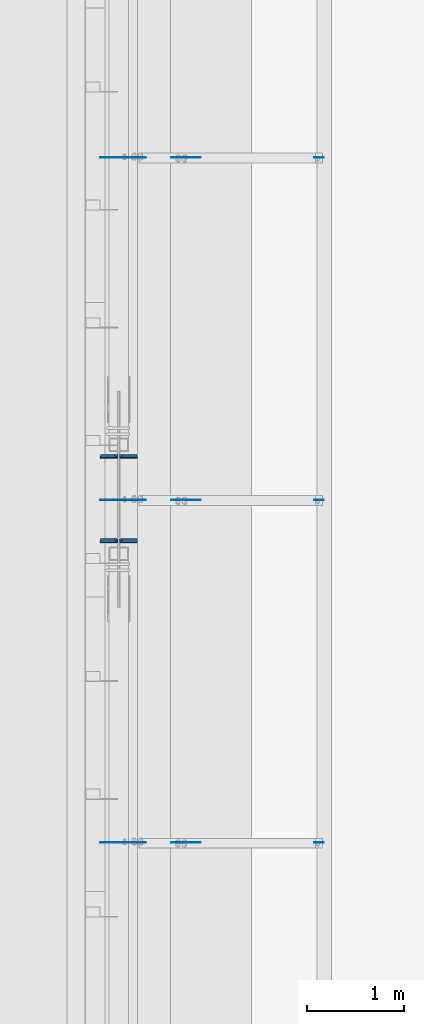
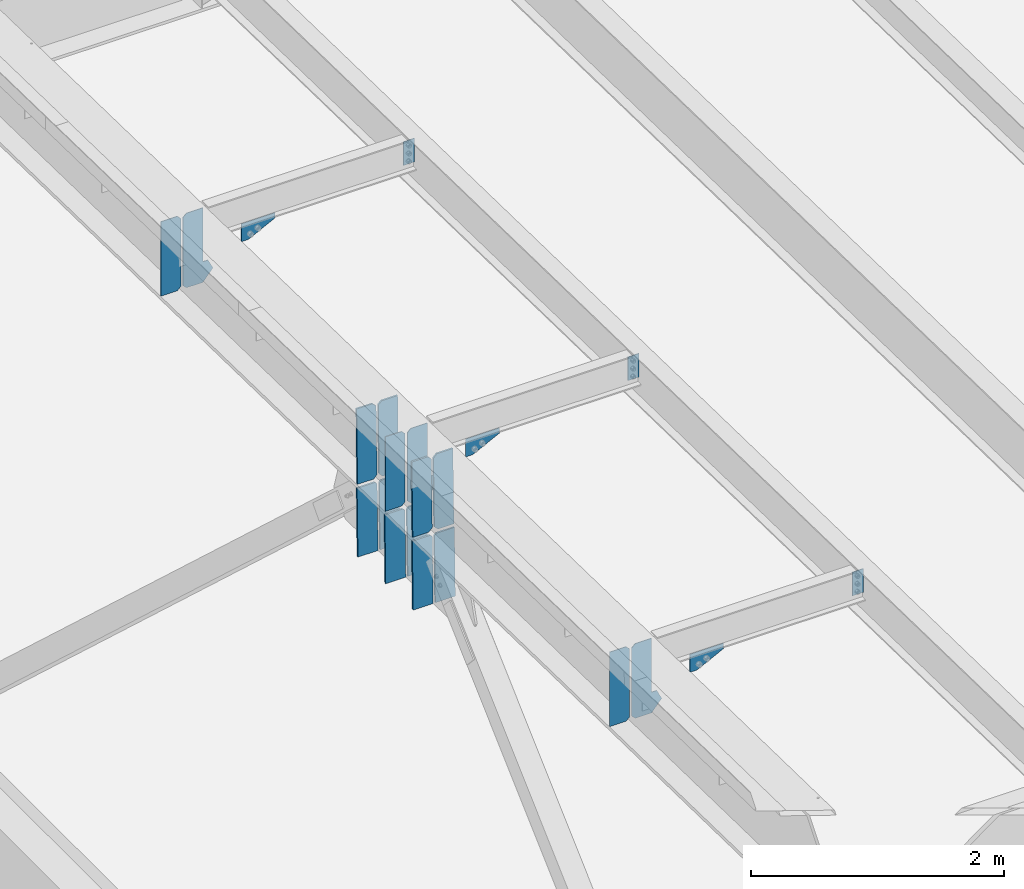
# One storey, part 1427 of 1763: 22 plates, 5 elements without a shape of their own.
"""IFC2X3 building model written with IfcOpenShell, lengths in millimetres."""

from ifc_helpers import new_model, si_unit, frame, origin_with_axes, place, context, subcontext, project, spatial, faceted_brep, material, type_object, element, aggregate, save


model = new_model("IFC2X3")

# Units and contexts
model_context = context("Model", 3, precision=1e-05, world=origin_with_axes())
body_context = subcontext(model_context, "Body", "Model", "MODEL_VIEW")
ifc_project = project(units=[si_unit("LENGTHUNIT", "METRE", prefix="MILLI"), si_unit("AREAUNIT", "SQUARE_METRE"), si_unit("VOLUMEUNIT", "CUBIC_METRE"), si_unit("MASSUNIT", "GRAM", prefix="KILO"), si_unit("TIMEUNIT", "SECOND"), si_unit("PLANEANGLEUNIT", "RADIAN"), si_unit("SOLIDANGLEUNIT", "STERADIAN"), si_unit("THERMODYNAMICTEMPERATUREUNIT", "DEGREE_CELSIUS"), si_unit("LUMINOUSINTENSITYUNIT", "LUMEN")], contexts=[model_context])

# Site, building, storey
site_placement = place(None, origin_with_axes())
site = spatial("IfcSite", under=ifc_project, at=site_placement, CompositionType="ELEMENT")
building_placement = place(site_placement, origin_with_axes())
building = spatial("IfcBuilding", under=site, at=building_placement, Name="Undefined", CompositionType="ELEMENT")
storey_placement = place(building_placement, origin_with_axes())
storey = spatial("IfcBuildingStorey", under=building, at=storey_placement, Name="Undefined", CompositionType="ELEMENT", Elevation=0.0)

# Assembly, plates
assembly_1_placement = place(storey_placement, origin_with_axes())
assembly_1 = element("IfcElementAssembly", 1, at=assembly_1_placement, inside=storey, Name="BEAM", AssemblyPlace="NOTDEFINED", PredefinedType="RIGID_FRAME")
ifc_material = material(Name="STEEL/A36")
plate_type_1 = type_object("IfcPlateType", PredefinedType="NOTDEFINED")
plate_1_placement = place(assembly_1_placement, frame((-85253.0631665555, -10166.3500000077, 12092.5240441116), z_axis=(-1.0, 0.0, 0.0), x_axis=(0.0, 0.0, -1.0)))
plate_1 = element("IfcPlate", 2, at=plate_1_placement, type_object=plate_type_1, material=ifc_material, Name="PLATE", context=body_context, shape_type="Brep", body=[
    faceted_brep([(1.81898940354586e-12, -3.17500000000291, 0.0), (0.0, -3.17499999999927, 101.599998474121), (0.0, 3.17499999999927, 101.599998474121), (-1.81898940354586e-12, 3.17499999997381, 0.0), (228.600006103516, -3.17499999999927, 101.599998474121), (228.600006103516, 3.17499999999927, 101.599998474121), (228.600006103516, -3.17500000001019, -7.27595761418343e-12), (228.600006103516, 3.17499999999563, -7.27595761418343e-12)], [[[0, 1, 2, 3]], [[1, 4, 5, 2]], [[4, 6, 7, 5]], [[6, 0, 3, 7]], [[5, 7, 3, 2]], [[6, 4, 1, 0]]]),
])
plate_2_placement = place(assembly_1_placement, frame((-85253.0631665555, -6623.04997029988, 12018.448086362), z_axis=(-1.0, 0.0, 0.0), x_axis=(0.0, 0.0, -1.0)))
plate_2 = element("IfcPlate", 3, at=plate_2_placement, type_object=plate_type_1, material=ifc_material, Name="PLATE", context=body_context, shape_type="Brep", body=[
    faceted_brep([(1.81898940354586e-12, -3.17500000000291, 0.0), (0.0, -3.17499999999927, 101.599998474121), (0.0, 3.17499999999927, 101.599998474121), (-1.81898940354586e-12, 3.17499999997381, 0.0), (228.600006103516, -3.17499999999927, 101.599998474121), (228.600006103516, 3.17499999999927, 101.599998474121), (228.600006103516, -3.17500000001019, -7.27595761418343e-12), (228.600006103516, 3.17499999999563, -7.27595761418343e-12)], [[[0, 1, 2, 3]], [[1, 4, 5, 2]], [[4, 6, 7, 5]], [[6, 0, 3, 7]], [[5, 7, 3, 2]], [[6, 4, 1, 0]]]),
])
plate_3_placement = place(assembly_1_placement, frame((-85253.0631665555, -3079.74999999648, 11944.3721298494), z_axis=(-1.0, 0.0, 0.0), x_axis=(0.0, 0.0, -1.0)))
plate_3 = element("IfcPlate", 4, at=plate_3_placement, type_object=plate_type_1, material=ifc_material, Name="PLATE", context=body_context, shape_type="Brep", body=[
    faceted_brep([(1.81898940354586e-12, -3.17500000000291, 0.0), (0.0, -3.17499999999927, 101.599998474121), (0.0, 3.17499999999927, 101.599998474121), (-1.81898940354586e-12, 3.17499999997381, 0.0), (228.600006103516, -3.17499999999927, 101.599998474121), (228.600006103516, 3.17499999999927, 101.599998474121), (228.600006103516, -3.17500000001019, -7.27595761418343e-12), (228.600006103516, 3.17499999999563, -7.27595761418343e-12)], [[[0, 1, 2, 3]], [[1, 4, 5, 2]], [[4, 6, 7, 5]], [[6, 0, 3, 7]], [[5, 7, 3, 2]], [[6, 4, 1, 0]]]),
])
aggregate(assembly_1, [plate_1, plate_2, plate_3])

assembly_2_placement = place(storey_placement, origin_with_axes())
assembly_2 = element("IfcElementAssembly", 5, at=assembly_2_placement, inside=storey, Name="BEAM", AssemblyPlace="NOTDEFINED", PredefinedType="RIGID_FRAME")
plate_type_2 = type_object("IfcPlateType", PredefinedType="NOTDEFINED")
plate_4_placement = place(assembly_2_placement, frame((-87384.9620473967, -3079.74999996299, 11230.3659606744), z_axis=(0.0, 0.0, 1.0), x_axis=(-1.0, 0.0, 0.0)))
plate_4 = element("IfcPlate", 6, at=plate_4_placement, type_object=plate_type_2, material=ifc_material, Name="PLATE", context=body_context, shape_type="Brep", body=[
    faceted_brep([(0.0, -3.17500000000291, 31.75), (0.0, -3.17499999999927, 686.812194824219), (0.0, 3.17499999999927, 686.812194824219), (0.0, 3.17500000000291, 31.75), (31.75, -3.17499999999927, 718.562194824219), (31.75, 3.17499999999927, 718.562194824219), (181.27522277832, -3.17500000000018, 718.562194824219), (181.27522277832, 3.17500000000018, 718.562194824219), (181.27522277832, -3.17500000000018, 0.0), (181.27522277832, 3.17500000000018, 0.0), (31.7499999999036, -3.17499999997381, 9.42916855706244e-11), (31.7499999998854, 3.17500000000291, 9.42916855706244e-11)], [[[0, 1, 2, 3]], [[1, 4, 5, 2]], [[4, 6, 7, 5]], [[6, 8, 9, 7]], [[8, 10, 11, 9]], [[10, 0, 3, 11]], [[5, 7, 9, 11, 3, 2]], [[10, 8, 6, 4, 1, 0]]]),
])
plate_5_placement = place(assembly_2_placement, frame((-87384.9620473967, -6623.04997026085, 11304.4419171798), z_axis=(0.0, 0.0, 1.0), x_axis=(-1.0, 0.0, 0.0)))
plate_5 = element("IfcPlate", 7, at=plate_5_placement, type_object=plate_type_2, material=ifc_material, Name="PLATE", context=body_context, shape_type="Brep", body=[
    faceted_brep([(0.0, -3.17500000000291, 31.75), (0.0, -3.17499999999927, 686.812194824219), (0.0, 3.17499999999927, 686.812194824219), (0.0, 3.17500000000291, 31.75), (31.75, -3.17499999999927, 718.562194824219), (31.75, 3.17499999999927, 718.562194824219), (181.27522277832, -3.17500000000018, 718.562194824219), (181.27522277832, 3.17500000000018, 718.562194824219), (181.27522277832, -3.17500000000018, 0.0), (181.27522277832, 3.17500000000018, 0.0), (31.7499999999036, -3.17499999997381, 9.42916855706244e-11), (31.7499999998854, 3.17500000000291, 9.42916855706244e-11)], [[[0, 1, 2, 3]], [[1, 4, 5, 2]], [[4, 6, 7, 5]], [[6, 8, 9, 7]], [[8, 10, 11, 9]], [[10, 0, 3, 11]], [[5, 7, 9, 11, 3, 2]], [[10, 8, 6, 4, 1, 0]]]),
])
plate_6_placement = place(assembly_2_placement, frame((-87384.9620473967, -10166.349999963, 11378.5178749269), z_axis=(0.0, 0.0, 1.0), x_axis=(-1.0, 0.0, 0.0)))
plate_6 = element("IfcPlate", 8, at=plate_6_placement, type_object=plate_type_2, material=ifc_material, Name="PLATE", context=body_context, shape_type="Brep", body=[
    faceted_brep([(0.0, -3.17500000000291, 31.75), (0.0, -3.17499999999927, 686.812194824219), (0.0, 3.17499999999927, 686.812194824219), (0.0, 3.17500000000291, 31.75), (31.75, -3.17499999999927, 718.562194824219), (31.75, 3.17499999999927, 718.562194824219), (181.27522277832, -3.17500000000018, 718.562194824219), (181.27522277832, 3.17500000000018, 718.562194824219), (181.27522277832, -3.17500000000018, 0.0), (181.27522277832, 3.17500000000018, 0.0), (31.7499999999036, -3.17499999997381, 9.42916855706244e-11), (31.7499999998854, 3.17500000000291, 9.42916855706244e-11)], [[[0, 1, 2, 3]], [[1, 4, 5, 2]], [[4, 6, 7, 5]], [[6, 8, 9, 7]], [[8, 10, 11, 9]], [[10, 0, 3, 11]], [[5, 7, 9, 11, 3, 2]], [[10, 8, 6, 4, 1, 0]]]),
])

# Assembly, plate
assembly_3_placement = place(storey_placement, origin_with_axes())
assembly_3 = element("IfcElementAssembly", 9, at=assembly_3_placement, inside=storey, Name="BEAM", AssemblyPlace="NOTDEFINED", PredefinedType="RIGID_FRAME")
plate_type_3 = type_object("IfcPlateType", PredefinedType="NOTDEFINED")
plate_7_placement = place(assembly_3_placement, frame((-86833.7627823412, -3079.75000001315, 11671.3220843818), z_axis=(1.0, 0.0, 0.0), x_axis=(0.0, 0.0, -1.0)))
plate_7 = element("IfcPlate", 10, at=plate_7_placement, type_object=plate_type_3, material=ifc_material, Name="PLATE", context=body_context, shape_type="Brep", body=[
    faceted_brep([(1.81898940354586e-12, -3.17500000000291, 0.0), (0.0, -3.17499999999927, 306.070465087891), (0.0, 3.17499999999927, 306.070465087891), (-1.81898940354586e-12, 3.17499999997381, 0.0), (50.7999992370605, -3.17499999999927, 306.070465087891), (50.7999992370605, 3.17499999999927, 306.070465087891), (172.922760009766, -3.17499999999927, 61.8249359130859), (172.922760009766, 3.17499999999927, 61.8249359130859), (172.922760009766, -3.17499999999927, 0.0), (172.922760009766, 3.17499999999927, 0.0)], [[[0, 1, 2, 3]], [[1, 4, 5, 2]], [[4, 6, 7, 5]], [[6, 8, 9, 7]], [[8, 0, 3, 9]], [[5, 7, 9, 3, 2]], [[8, 6, 4, 1, 0]]]),
])
aggregate(assembly_3, [plate_7])

assembly_4_placement = place(storey_placement, origin_with_axes())
assembly_4 = element("IfcElementAssembly", 11, at=assembly_4_placement, inside=storey, Name="BEAM", AssemblyPlace="NOTDEFINED", PredefinedType="RIGID_FRAME")
plate_8_placement = place(assembly_4_placement, frame((-86833.7627823412, -6623.04997031101, 11745.3980408872), z_axis=(1.0, 0.0, 0.0), x_axis=(0.0, 0.0, -1.0)))
plate_8 = element("IfcPlate", 12, at=plate_8_placement, type_object=plate_type_3, material=ifc_material, Name="PLATE", context=body_context, shape_type="Brep", body=[
    faceted_brep([(1.81898940354586e-12, -3.17500000000291, 0.0), (0.0, -3.17499999999927, 306.070465087891), (0.0, 3.17499999999927, 306.070465087891), (-1.81898940354586e-12, 3.17499999997381, 0.0), (50.7999992370605, -3.17499999999927, 306.070465087891), (50.7999992370605, 3.17499999999927, 306.070465087891), (172.922760009766, -3.17499999999927, 61.8249359130859), (172.922760009766, 3.17499999999927, 61.8249359130859), (172.922760009766, -3.17499999999927, 0.0), (172.922760009766, 3.17499999999927, 0.0)], [[[0, 1, 2, 3]], [[1, 4, 5, 2]], [[4, 6, 7, 5]], [[6, 8, 9, 7]], [[8, 0, 3, 9]], [[5, 7, 9, 3, 2]], [[8, 6, 4, 1, 0]]]),
])
aggregate(assembly_4, [plate_8])

assembly_5_placement = place(storey_placement, origin_with_axes())
assembly_5 = element("IfcElementAssembly", 13, at=assembly_5_placement, inside=storey, Name="BEAM", AssemblyPlace="NOTDEFINED", PredefinedType="RIGID_FRAME")
plate_9_placement = place(assembly_5_placement, frame((-86833.7627823412, -10166.3500000131, 11819.4739986343), z_axis=(1.0, 0.0, 0.0), x_axis=(0.0, 0.0, -1.0)))
plate_9 = element("IfcPlate", 14, at=plate_9_placement, type_object=plate_type_3, material=ifc_material, Name="PLATE", context=body_context, shape_type="Brep", body=[
    faceted_brep([(1.81898940354586e-12, -3.17500000000291, 0.0), (0.0, -3.17499999999927, 306.070465087891), (0.0, 3.17499999999927, 306.070465087891), (-1.81898940354586e-12, 3.17499999997381, 0.0), (50.7999992370605, -3.17499999999927, 306.070465087891), (50.7999992370605, 3.17499999999927, 306.070465087891), (172.922760009766, -3.17499999999927, 61.8249359130859), (172.922760009766, 3.17499999999927, 61.8249359130859), (172.922760009766, -3.17499999999927, 0.0), (172.922760009766, 3.17499999999927, 0.0)], [[[0, 1, 2, 3]], [[1, 4, 5, 2]], [[4, 6, 7, 5]], [[6, 8, 9, 7]], [[8, 0, 3, 9]], [[5, 7, 9, 3, 2]], [[8, 6, 4, 1, 0]]]),
])
aggregate(assembly_5, [plate_9])

# Plate
plate_type_4 = type_object("IfcPlateType", PredefinedType="NOTDEFINED")
plate_10_placement = place(assembly_2_placement, frame((-87365.9120473967, -3079.74999996487, 11230.3659606744), z_axis=(0.0, 0.0, 1.0), x_axis=(1.0, 0.0, 0.0)))
plate_10 = element("IfcPlate", 15, at=plate_10_placement, type_object=plate_type_4, material=ifc_material, Name="PLATE", context=body_context, shape_type="Brep", body=[
    faceted_brep([(0.0, -3.17500000000291, 31.75), (0.0, -3.17499999999927, 686.812255859375), (0.0, 3.17499999999927, 686.812255859375), (0.0, 3.17500000000291, 31.75), (31.75, -3.17499999999927, 718.562255859375), (31.75, 3.17499999999927, 718.562255859375), (182.562271118164, -3.17500000000018, 718.562255859375), (182.562271118164, 3.17500000000018, 718.562255859375), (182.562271118164, -3.17500000000018, 199.174194335938), (182.562271118164, 3.17500000000018, 199.174194335938), (229.018508911133, -3.17500000000018, 199.147766113281), (229.018508911133, 3.17500000000018, 199.147766113281), (274.455413818359, -3.17500000000018, 108.273963928223), (274.455413818359, 3.17500000000018, 108.273963928223), (182.562271118164, -3.17500000000018, 0.0), (182.562271118164, 3.17500000000018, 0.0), (31.7499999999036, -3.17499999997381, 9.42916855706244e-11), (31.7499999998854, 3.17500000000291, 9.42916855706244e-11)], [[[0, 1, 2, 3]], [[1, 4, 5, 2]], [[4, 6, 7, 5]], [[6, 8, 9, 7]], [[8, 10, 11, 9]], [[10, 12, 13, 11]], [[12, 14, 15, 13]], [[14, 16, 17, 15]], [[16, 0, 3, 17]], [[5, 7, 9, 11, 13, 15, 17, 3, 2]], [[16, 14, 12, 10, 8, 6, 4, 1, 0]]]),
])

plate_11_placement = place(assembly_2_placement, frame((-87365.9120473967, -6623.04997026273, 11304.4419171798), z_axis=(0.0, 0.0, 1.0), x_axis=(1.0, 0.0, 0.0)))
plate_11 = element("IfcPlate", 16, at=plate_11_placement, type_object=plate_type_4, material=ifc_material, Name="PLATE", context=body_context, shape_type="Brep", body=[
    faceted_brep([(0.0, -3.17500000000291, 31.75), (0.0, -3.17499999999927, 686.812255859375), (0.0, 3.17499999999927, 686.812255859375), (0.0, 3.17500000000291, 31.75), (31.75, -3.17499999999927, 718.562255859375), (31.75, 3.17499999999927, 718.562255859375), (182.562271118164, -3.17500000000018, 718.562255859375), (182.562271118164, 3.17500000000018, 718.562255859375), (182.562271118164, -3.17500000000018, 199.174194335938), (182.562271118164, 3.17500000000018, 199.174194335938), (229.018508911133, -3.17500000000018, 199.147766113281), (229.018508911133, 3.17500000000018, 199.147766113281), (274.455413818359, -3.17500000000018, 108.273963928223), (274.455413818359, 3.17500000000018, 108.273963928223), (182.562271118164, -3.17500000000018, 0.0), (182.562271118164, 3.17500000000018, 0.0), (31.7499999999036, -3.17499999997381, 9.42916855706244e-11), (31.7499999998854, 3.17500000000291, 9.42916855706244e-11)], [[[0, 1, 2, 3]], [[1, 4, 5, 2]], [[4, 6, 7, 5]], [[6, 8, 9, 7]], [[8, 10, 11, 9]], [[10, 12, 13, 11]], [[12, 14, 15, 13]], [[14, 16, 17, 15]], [[16, 0, 3, 17]], [[5, 7, 9, 11, 13, 15, 17, 3, 2]], [[16, 14, 12, 10, 8, 6, 4, 1, 0]]]),
])

plate_12_placement = place(assembly_2_placement, frame((-87365.9120473967, -10166.3499999649, 11378.5178749269), z_axis=(0.0, 0.0, 1.0), x_axis=(1.0, 0.0, 0.0)))
plate_12 = element("IfcPlate", 17, at=plate_12_placement, type_object=plate_type_4, material=ifc_material, Name="PLATE", context=body_context, shape_type="Brep", body=[
    faceted_brep([(0.0, -3.17500000000291, 31.75), (0.0, -3.17499999999927, 686.812255859375), (0.0, 3.17499999999927, 686.812255859375), (0.0, 3.17500000000291, 31.75), (31.75, -3.17499999999927, 718.562255859375), (31.75, 3.17499999999927, 718.562255859375), (182.562271118164, -3.17500000000018, 718.562255859375), (182.562271118164, 3.17500000000018, 718.562255859375), (182.562271118164, -3.17500000000018, 199.174194335938), (182.562271118164, 3.17500000000018, 199.174194335938), (229.018508911133, -3.17500000000018, 199.147766113281), (229.018508911133, 3.17500000000018, 199.147766113281), (274.455413818359, -3.17500000000018, 108.273963928223), (274.455413818359, 3.17500000000018, 108.273963928223), (182.562271118164, -3.17500000000018, 0.0), (182.562271118164, 3.17500000000018, 0.0), (31.7499999999036, -3.17499999997381, 9.42916855706244e-11), (31.7499999998854, 3.17500000000291, 9.42916855706244e-11)], [[[0, 1, 2, 3]], [[1, 4, 5, 2]], [[4, 6, 7, 5]], [[6, 8, 9, 7]], [[8, 10, 11, 9]], [[10, 12, 13, 11]], [[12, 14, 15, 13]], [[14, 16, 17, 15]], [[16, 0, 3, 17]], [[5, 7, 9, 11, 13, 15, 17, 3, 2]], [[16, 14, 12, 10, 8, 6, 4, 1, 0]]]),
])

plate_type_5 = type_object("IfcPlateType", PredefinedType="NOTDEFINED")
plate_13_placement = place(assembly_2_placement, frame((-87188.1122736984, -6173.93912562898, 11294.3868374917), z_axis=(0.0, 0.0209013539966291, 0.999781542838788), x_axis=(-1.0, 0.0, 0.0)))
plate_13 = element("IfcPlate", 18, at=plate_13_placement, type_object=plate_type_5, material=ifc_material, Name="PLATE", context=body_context, shape_type="Brep", body=[
    faceted_brep([(-7.27595761418343e-12, -7.9375, 0.0), (0.0, -7.93750000023556, 717.549987793544), (0.0, 7.93749999976308, 717.549987793549), (-7.27595761418343e-12, 7.9375, 0.0), (146.050003051758, -7.93750000023556, 717.549987793544), (146.050003051758, 7.93749999976308, 717.549987793549), (177.800003051758, -7.93750000022555, 685.799987793518), (177.800003051758, 7.93749999977354, 685.799987793525), (177.800003051758, -7.93750000001, 31.7500000000236), (177.800003051758, 7.93749999998863, 31.7500000000309), (146.050003051758, -7.9375, 0.0), (146.050003051758, 7.93749999999909, 3.63797880709171e-12)], [[[0, 1, 2, 3]], [[1, 4, 5, 2]], [[4, 6, 7, 5]], [[6, 8, 9, 7]], [[8, 10, 11, 9]], [[10, 0, 3, 11]], [[5, 7, 9, 11, 3, 2]], [[10, 8, 6, 4, 1, 0]]]),
])

plate_14_placement = place(assembly_2_placement, frame((-87384.9622736983, -6173.93912562898, 11294.3868374917), z_axis=(0.0, 0.0209013539966291, 0.999781542838788), x_axis=(-1.0, 0.0, 0.0)))
plate_14 = element("IfcPlate", 19, at=plate_14_placement, type_object=plate_type_5, material=ifc_material, Name="PLATE", context=body_context, shape_type="Brep", body=[
    faceted_brep([(0.0, -7.9375, 31.75), (0.0, -7.93750000022555, 685.799987793518), (0.0, 7.93749999977354, 685.799987793525), (0.0, 7.9375, 31.75), (31.75, -7.93750000023556, 717.549987793544), (31.75, 7.93749999976262, 717.549987793549), (177.800003051758, -7.93750000023556, 717.549987793544), (177.800003051758, 7.93749999976262, 717.549987793549), (177.800003051758, -7.9375, 0.0), (177.800003051758, 7.93749999999909, 3.63797880709171e-12), (31.75, -7.9375, 0.0), (31.75, 7.9375, 0.0)], [[[0, 1, 2, 3]], [[1, 4, 5, 2]], [[4, 6, 7, 5]], [[6, 8, 9, 7]], [[8, 10, 11, 9]], [[10, 0, 3, 11]], [[5, 7, 9, 11, 3, 2]], [[10, 8, 6, 4, 1, 0]]]),
])

plate_15_placement = place(assembly_2_placement, frame((-87188.1122736984, -7046.33856760696, 11312.6251530906), z_axis=(0.0, 0.0209013539966291, 0.999781542838788), x_axis=(-1.0, 0.0, 0.0)))
plate_15 = element("IfcPlate", 20, at=plate_15_placement, type_object=plate_type_5, material=ifc_material, Name="PLATE", context=body_context, shape_type="Brep", body=[
    faceted_brep([(-7.27595761418343e-12, -7.9375, 0.0), (0.0, -7.93750000023556, 717.549987793544), (0.0, 7.93749999976308, 717.549987793549), (-7.27595761418343e-12, 7.9375, 0.0), (146.050003051758, -7.93750000023556, 717.549987793544), (146.050003051758, 7.93749999976308, 717.549987793549), (177.800003051758, -7.93750000022555, 685.799987793518), (177.800003051758, 7.93749999977354, 685.799987793525), (177.800003051758, -7.93750000001, 31.7500000000236), (177.800003051758, 7.93749999998863, 31.7500000000309), (146.050003051758, -7.9375, 0.0), (146.050003051758, 7.93749999999909, 3.63797880709171e-12)], [[[0, 1, 2, 3]], [[1, 4, 5, 2]], [[4, 6, 7, 5]], [[6, 8, 9, 7]], [[8, 10, 11, 9]], [[10, 0, 3, 11]], [[5, 7, 9, 11, 3, 2]], [[10, 8, 6, 4, 1, 0]]]),
])

plate_16_placement = place(assembly_2_placement, frame((-87384.9622736983, -7046.33856760696, 11312.6251530906), z_axis=(0.0, 0.0209013539966291, 0.999781542838788), x_axis=(-1.0, 0.0, 0.0)))
plate_16 = element("IfcPlate", 21, at=plate_16_placement, type_object=plate_type_5, material=ifc_material, Name="PLATE", context=body_context, shape_type="Brep", body=[
    faceted_brep([(0.0, -7.9375, 31.75), (0.0, -7.93750000022555, 685.799987793518), (0.0, 7.93749999977354, 685.799987793525), (0.0, 7.9375, 31.75), (31.75, -7.93750000023556, 717.549987793544), (31.75, 7.93749999976262, 717.549987793549), (177.800003051758, -7.93750000023556, 717.549987793544), (177.800003051758, 7.93749999976262, 717.549987793549), (177.800003051758, -7.9375, 0.0), (177.800003051758, 7.93749999999909, 3.63797880709171e-12), (31.75, -7.9375, 0.0), (31.75, 7.9375, 0.0)], [[[0, 1, 2, 3]], [[1, 4, 5, 2]], [[4, 6, 7, 5]], [[6, 8, 9, 7]], [[8, 10, 11, 9]], [[10, 0, 3, 11]], [[5, 7, 9, 11, 3, 2]], [[10, 8, 6, 4, 1, 0]]]),
])

plate_type_6 = type_object("IfcPlateType", PredefinedType="NOTDEFINED")
plate_17_placement = place(assembly_2_placement, frame((-87384.9622736979, -7047.06804744363, 11277.7077722575), z_axis=(0.0, -0.0209013569953167, -0.999781542776098), x_axis=(-1.0, 0.0, 0.0)))
plate_17 = element("IfcPlate", 22, at=plate_17_placement, type_object=plate_type_6, material=ifc_material, Name="PLATE", context=body_context, shape_type="Brep", body=[
    faceted_brep([(-3.27418092638254e-10, -7.9375, 19.0499992370605), (0.0, -7.93750000021555, 655.64782714896), (0.0, 7.93749999978263, 655.647827148967), (-3.27418092638254e-10, 7.9375, 19.0499992370605), (182.5625, -7.93750000021555, 655.64782714896), (182.5625, 7.93749999978263, 655.647827148967), (182.5625, -7.9375, -5.45696821063757e-12), (182.5625, 7.93749999999909, -1.81898940354586e-12), (19.0499815529183, -7.9375, 0.0), (19.0499815529183, 7.9375, 0.0)], [[[0, 1, 2, 3]], [[1, 4, 5, 2]], [[4, 6, 7, 5]], [[6, 8, 9, 7]], [[8, 0, 3, 9]], [[5, 7, 9, 3, 2]], [[8, 6, 4, 1, 0]]]),
])

plate_18_placement = place(assembly_2_placement, frame((-87183.3497736981, -7047.06804744501, 11277.7077723329), z_axis=(0.0, -0.0209013569953167, -0.999781542776098), x_axis=(-1.0, 0.0, 0.0)))
plate_18 = element("IfcPlate", 23, at=plate_18_placement, type_object=plate_type_6, material=ifc_material, Name="PLATE", context=body_context, shape_type="Brep", body=[
    faceted_brep([(-7.27595761418343e-12, -7.9375, 0.0), (0.0, -7.93750000021555, 655.64782714896), (0.0, 7.93749999978263, 655.647827148967), (-7.27595761418343e-12, 7.9375, 0.0), (182.5625, -7.93750000021555, 655.64782714896), (182.5625, 7.93749999978263, 655.647827148967), (182.5625, -7.93750000000637, 19.0499992370715), (182.5625, 7.93749999999181, 19.0499992370769), (163.512500762939, -7.93750000000091, -3.63797880709171e-12), (163.512500762939, 7.93749999999818, 1.81898940354586e-12)], [[[0, 1, 2, 3]], [[1, 4, 5, 2]], [[4, 6, 7, 5]], [[6, 8, 9, 7]], [[8, 0, 3, 9]], [[5, 7, 9, 3, 2]], [[8, 6, 4, 1, 0]]]),
])

plate_19_placement = place(assembly_2_placement, frame((-87384.9622736981, -6174.66860545944, 11259.4694569555), z_axis=(0.0, -0.0209013569953167, -0.999781542776098), x_axis=(-1.0, 0.0, 0.0)))
plate_19 = element("IfcPlate", 24, at=plate_19_placement, type_object=plate_type_6, material=ifc_material, Name="PLATE", context=body_context, shape_type="Brep", body=[
    faceted_brep([(-3.27418092638254e-10, -7.9375, 19.0499992370605), (0.0, -7.93750000021555, 655.64782714896), (0.0, 7.93749999978263, 655.647827148967), (-3.27418092638254e-10, 7.9375, 19.0499992370605), (182.5625, -7.93750000021555, 655.64782714896), (182.5625, 7.93749999978263, 655.647827148967), (182.5625, -7.9375, -5.45696821063757e-12), (182.5625, 7.93749999999909, -1.81898940354586e-12), (19.0499815529183, -7.9375, 0.0), (19.0499815529183, 7.9375, 0.0)], [[[0, 1, 2, 3]], [[1, 4, 5, 2]], [[4, 6, 7, 5]], [[6, 8, 9, 7]], [[8, 0, 3, 9]], [[5, 7, 9, 3, 2]], [[8, 6, 4, 1, 0]]]),
])

plate_20_placement = place(assembly_2_placement, frame((-87384.9622736983, -6613.44300291686, 11268.6424400736), z_axis=(0.0, -0.0209013569953167, -0.999781542776098), x_axis=(-1.0, 0.0, 0.0)))
plate_20 = element("IfcPlate", 25, at=plate_20_placement, type_object=plate_type_6, material=ifc_material, Name="PLATE", context=body_context, shape_type="Brep", body=[
    faceted_brep([(-3.27418092638254e-10, -7.9375, 19.0499992370605), (0.0, -7.93750000021555, 655.64782714896), (0.0, 7.93749999978263, 655.647827148967), (-3.27418092638254e-10, 7.9375, 19.0499992370605), (182.5625, -7.93750000021555, 655.64782714896), (182.5625, 7.93749999978263, 655.647827148967), (182.5625, -7.9375, -5.45696821063757e-12), (182.5625, 7.93749999999909, -1.81898940354586e-12), (19.0499815529183, -7.9375, 0.0), (19.0499815529183, 7.9375, 0.0)], [[[0, 1, 2, 3]], [[1, 4, 5, 2]], [[4, 6, 7, 5]], [[6, 8, 9, 7]], [[8, 0, 3, 9]], [[5, 7, 9, 3, 2]], [[8, 6, 4, 1, 0]]]),
])

plate_21_placement = place(assembly_2_placement, frame((-87183.349773698, -6174.66860545944, 11259.4694569555), z_axis=(0.0, -0.0209013569953167, -0.999781542776098), x_axis=(-1.0, 0.0, 0.0)))
plate_21 = element("IfcPlate", 26, at=plate_21_placement, type_object=plate_type_6, material=ifc_material, Name="PLATE", context=body_context, shape_type="Brep", body=[
    faceted_brep([(-7.27595761418343e-12, -7.9375, 0.0), (0.0, -7.93750000021555, 655.64782714896), (0.0, 7.93749999978263, 655.647827148967), (-7.27595761418343e-12, 7.9375, 0.0), (182.5625, -7.93750000021555, 655.64782714896), (182.5625, 7.93749999978263, 655.647827148967), (182.5625, -7.93750000000637, 19.0499992370715), (182.5625, 7.93749999999181, 19.0499992370769), (163.512500762939, -7.93750000000091, -3.63797880709171e-12), (163.512500762939, 7.93749999999818, 1.81898940354586e-12)], [[[0, 1, 2, 3]], [[1, 4, 5, 2]], [[4, 6, 7, 5]], [[6, 8, 9, 7]], [[8, 0, 3, 9]], [[5, 7, 9, 3, 2]], [[8, 6, 4, 1, 0]]]),
])

plate_22_placement = place(assembly_2_placement, frame((-87183.3497736983, -6613.44300291687, 11268.6424400736), z_axis=(0.0, -0.0209013569953167, -0.999781542776098), x_axis=(-1.0, 0.0, 0.0)))
plate_22 = element("IfcPlate", 27, at=plate_22_placement, type_object=plate_type_6, material=ifc_material, Name="PLATE", context=body_context, shape_type="Brep", body=[
    faceted_brep([(-7.27595761418343e-12, -7.9375, 0.0), (0.0, -7.93750000021555, 655.64782714896), (0.0, 7.93749999978263, 655.647827148967), (-7.27595761418343e-12, 7.9375, 0.0), (182.5625, -7.93750000021555, 655.64782714896), (182.5625, 7.93749999978263, 655.647827148967), (182.5625, -7.93750000000637, 19.0499992370715), (182.5625, 7.93749999999181, 19.0499992370769), (163.512500762939, -7.93750000000091, -3.63797880709171e-12), (163.512500762939, 7.93749999999818, 1.81898940354586e-12)], [[[0, 1, 2, 3]], [[1, 4, 5, 2]], [[4, 6, 7, 5]], [[6, 8, 9, 7]], [[8, 0, 3, 9]], [[5, 7, 9, 3, 2]], [[8, 6, 4, 1, 0]]]),
])

aggregate(assembly_2, [plate_4, plate_10, plate_5, plate_11, plate_6, plate_12, plate_13, plate_14, plate_15, plate_16, plate_17, plate_18, plate_19, plate_20, plate_21, plate_22])

save(model, "model.ifc")
